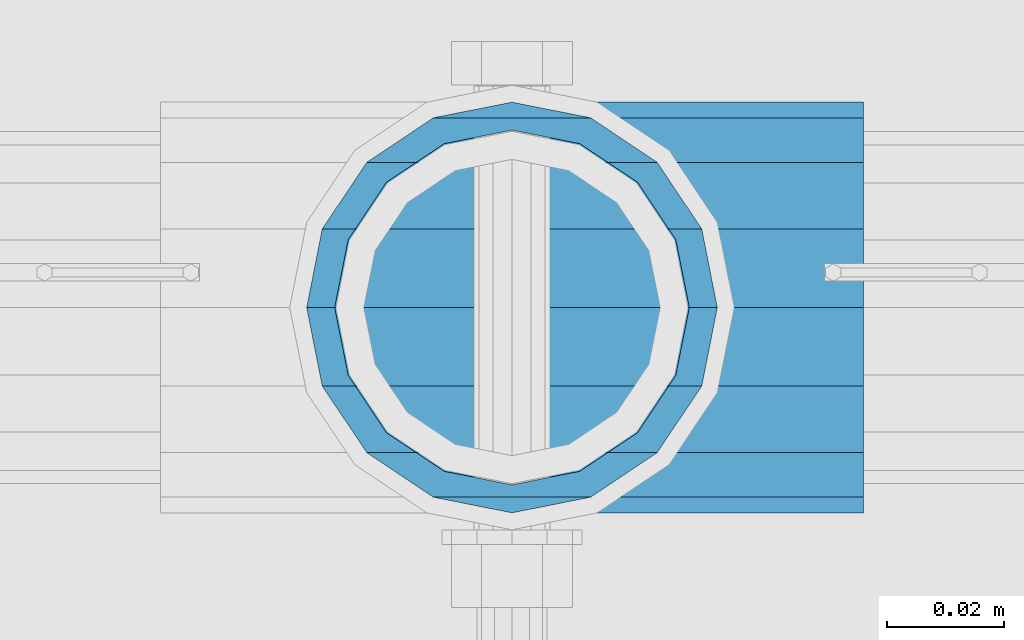
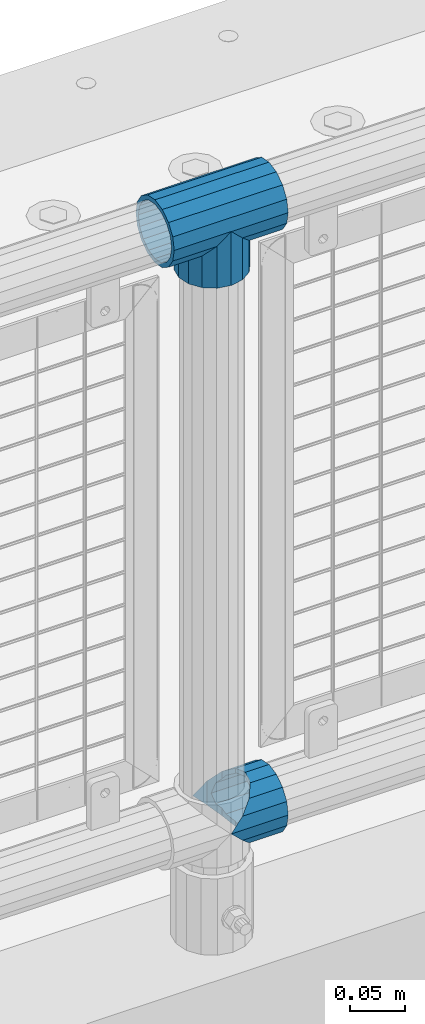
# One storey, part 144 of 242: 3 beams.
"""IFC2X3 building model written with IfcOpenShell, lengths in millimetres."""

import ifcopenshell
import ifcopenshell.guid

model = None  # the IFC model being written
_history = None  # IfcOwnerHistory: only IFC2X3 demands one
_inside = {}  # id of a spatial element -> (the spatial element, [elements in it])
_under = {}  # id of a project, library or spatial element -> (it, [spatial elements below it])
_declared = {}  # id of a project -> (the project, [libraries it declares])
_typed = {}  # id of a type object -> (the type object, [elements of that type])
_made_of = {}  # id of a material, layer set ... -> (it, [elements and type objects made of it])


def new_model(schema):
    """Start an empty IFC model of exactly this schema.

    Asked for "IFC4X3", IfcOpenShell would pick the latest addendum, in which some entities
    have other attributes; the version numbers below select the first issue.
    IFC2X3 requires an IfcOwnerHistory on every rooted entity: one is made here for all.
    """
    global model, _history
    if schema == "IFC4X3":
        model = ifcopenshell.file(schema_version=(4, 3, 0, 0))
    else:
        model = ifcopenshell.file(schema=schema)
    _inside.clear()
    _under.clear()
    _declared.clear()
    _typed.clear()
    _made_of.clear()
    _history = None
    if model.schema == "IFC2X3":
        org = make("IfcOrganization", Name="unknown")
        user = make(
            "IfcPersonAndOrganization",
            ThePerson=make("IfcPerson", FamilyName="unknown"),
            TheOrganization=org,
        )
        app = make(
            "IfcApplication",
            ApplicationDeveloper=org,
            Version="unknown",
            ApplicationFullName="unknown",
            ApplicationIdentifier="unknown",
        )
        _history = make(
            "IfcOwnerHistory",
            OwningUser=user,
            OwningApplication=app,
            ChangeAction="ADDED",
            CreationDate=0,
        )
    return model


def make(cls, **values):
    """One entity of the class cls with the attributes given. An attribute that is None is left unset."""
    return model.create_entity(
        cls, **{name: value for name, value in values.items() if value is not None}
    )


def rooted(cls, **values):
    """An entity with a GlobalId (a new one), such as an element, a storey or a relation."""
    return make(cls, GlobalId=ifcopenshell.guid.new(), OwnerHistory=_history, **values)


def si_unit(unit_type, name, prefix=None):
    """IfcSIUnit, for example si_unit("LENGTHUNIT", "METRE", prefix="MILLI")."""
    return make("IfcSIUnit", UnitType=unit_type, Prefix=prefix, Name=name)


def assignment(units):
    """IfcUnitAssignment: the units of a project."""
    return None if units is None else make("IfcUnitAssignment", Units=units)


def point(xyz):
    """IfcCartesianPoint."""
    return None if xyz is None else make("IfcCartesianPoint", Coordinates=xyz)


def direction(xyz):
    """IfcDirection."""
    return None if xyz is None else make("IfcDirection", DirectionRatios=xyz)


def frame(location, z_axis=None, x_axis=None):
    """IfcAxis2Placement3D, a coordinate frame: its origin and axes. An axis left out is left unset."""
    return make(
        "IfcAxis2Placement3D",
        Location=point(location),
        Axis=direction(z_axis),
        RefDirection=direction(x_axis),
    )


def origin_with_axes():
    """The frame at (0, 0, 0) with the z axis (0, 0, 1) and the x axis (1, 0, 0) written out."""
    return frame((0.0, 0.0, 0.0), z_axis=(0.0, 0.0, 1.0), x_axis=(1.0, 0.0, 0.0))


def place(relative_to, where):
    """IfcLocalPlacement: puts the frame where relative to a parent placement (None: the world)."""
    return make(
        "IfcLocalPlacement", PlacementRelTo=relative_to, RelativePlacement=where
    )


def context(
    kind, dimensions, precision=None, world=None, true_north=None, identifier=None
):
    """IfcGeometricRepresentationContext, for example the 3D "Model" context."""
    return make(
        "IfcGeometricRepresentationContext",
        ContextIdentifier=identifier,
        ContextType=kind,
        CoordinateSpaceDimension=dimensions,
        Precision=precision,
        WorldCoordinateSystem=world,
        TrueNorth=true_north,
    )


def subcontext(parent, identifier, kind, view, scale=None):
    """IfcGeometricRepresentationSubContext, for example "Body" below "Model"."""
    return make(
        "IfcGeometricRepresentationSubContext",
        ContextIdentifier=identifier,
        ContextType=kind,
        ParentContext=parent,
        TargetScale=scale,
        TargetView=view,
    )


def project(units=None, contexts=None):
    """IfcProject with its units and contexts."""
    return rooted(
        "IfcProject",
        Name="project",
        RepresentationContexts=contexts,
        UnitsInContext=assignment(units),
    )


def spatial(cls, under=None, at=None, **own):
    """A site, building, storey or space (cls), placed at a placement, below another one or the project."""
    s = rooted(cls, ObjectPlacement=at, **own)
    if under is not None:
        _under.setdefault(under.id(), (under, []))[1].append(s)
    return s


def faces_of(points, faces, orient=None, outer=None):
    """IfcFace entities. A face is a list of loops; a loop is a list of indices into points, from 0.

    orient and outer hold one flag for each loop. By default every Orientation is true, the
    first loop of a face is its IfcFaceOuterBound and the others are IfcFaceBound.
    """
    made = []
    for i, loops in enumerate(faces):
        bounds = []
        for j, loop in enumerate(loops):
            is_outer = j == 0 if outer is None else outer[i][j]
            bounds.append(
                make(
                    "IfcFaceOuterBound" if is_outer else "IfcFaceBound",
                    Bound=make("IfcPolyLoop", Polygon=[points[k] for k in loop]),
                    Orientation=True if orient is None else orient[i][j],
                )
            )
        made.append(make("IfcFace", Bounds=bounds))
    return made


def faceted_brep(points, faces, orient=None, outer=None, voids=None):
    """IfcFacetedBrep: a solid bounded by flat faces; with voids (closed shells), ...WithVoids."""
    shared = [point(p) for p in points]
    hull = make("IfcClosedShell", CfsFaces=faces_of(shared, faces, orient, outer))
    if voids is None:
        return make("IfcFacetedBrep", Outer=hull)
    return make(
        "IfcFacetedBrepWithVoids",
        Outer=hull,
        Voids=[
            make(cls, CfsFaces=faces_of(shared, fs, o, b)) for cls, fs, o, b in voids
        ],
    )


def shape(context_of_items, identifier, shape_type, items):
    """IfcShapeRepresentation: the items that make up one representation, for example the "Body"."""
    return make(
        "IfcShapeRepresentation",
        ContextOfItems=context_of_items,
        RepresentationIdentifier=identifier,
        RepresentationType=shape_type,
        Items=items,
    )


def material(Name=None, Category=None):
    """IfcMaterial."""
    return make("IfcMaterial", Name=Name, Category=Category)


def made_of(thing, what):
    """Note that an element or type object is made of a material, layer set ...; save() writes the relation."""
    if what is not None:
        _made_of.setdefault(what.id(), (what, []))[1].append(thing)
    return thing


def type_object(cls, material=None, **own):
    """A type object (cls), such as IfcWallType, which elements share."""
    return made_of(rooted(cls, **own), material)


def element(
    cls,
    number,
    at=None,
    inside=None,
    cuts=None,
    type_object=None,
    material=None,
    context=None,
    identifier="Body",
    shape_type=None,
    held_by="IfcProductDefinitionShape",
    body=None,
    shapes=None,
    **own,
):
    """One element of the class cls, such as IfcWall. Its Tag is "e" and its number.

    at: its placement. inside: the storey or other place that contains it. cuts: it is an
    opening in that element (IfcRelVoidsElement). A single representation is given by context,
    identifier, shape_type and body (its items); several are given by shapes. held_by: the class
    of the entity that holds the representations. save() writes the other relations.
    """
    e = rooted(cls, Tag="e%d" % number, ObjectPlacement=at, **own)
    if body is not None:
        shapes = [shape(context, identifier, shape_type, body)]
    if shapes is not None:
        e.Representation = make(held_by, Representations=shapes)
    if inside is not None:
        _inside.setdefault(inside.id(), (inside, []))[1].append(e)
    if cuts is not None:
        rooted(
            "IfcRelVoidsElement", RelatingBuildingElement=cuts, RelatedOpeningElement=e
        )
    if type_object is not None:
        _typed.setdefault(type_object.id(), (type_object, []))[1].append(e)
    return made_of(e, material)


def aggregate(whole, parts):
    """IfcRelAggregates: a whole, such as a stair, and the parts it consists of."""
    return rooted("IfcRelAggregates", RelatingObject=whole, RelatedObjects=parts)


def save(model, path):
    """Write the relations noted so far, then the file.

    IfcRelAggregates (storeys below a building ...), IfcRelContainedInSpatialStructure (elements
    in a storey), IfcRelDefinesByType, IfcRelAssociatesMaterial and IfcRelDeclares: one each for
    every whole, place, type object, material and project.
    """
    for whole, parts in _under.values():
        aggregate(whole, parts)
    for where, things in _inside.values():
        rooted(
            "IfcRelContainedInSpatialStructure",
            RelatedElements=things,
            RelatingStructure=where,
        )
    for kind, things in _typed.values():
        rooted("IfcRelDefinesByType", RelatedObjects=things, RelatingType=kind)
    for what, things in _made_of.values():
        rooted("IfcRelAssociatesMaterial", RelatedObjects=things, RelatingMaterial=what)
    for by, libraries in _declared.values():
        rooted("IfcRelDeclares", RelatingContext=by, RelatedDefinitions=libraries)
    model.write(path)


model = new_model("IFC2X3")

# Units and contexts
model_context = context("Model", 3, precision=1e-05, world=origin_with_axes())
body_context = subcontext(model_context, "Body", "Model", "MODEL_VIEW")
ifc_project = project(units=[si_unit("LENGTHUNIT", "METRE", prefix="MILLI"), si_unit("AREAUNIT", "SQUARE_METRE"), si_unit("VOLUMEUNIT", "CUBIC_METRE"), si_unit("MASSUNIT", "GRAM", prefix="KILO"), si_unit("TIMEUNIT", "SECOND"), si_unit("PLANEANGLEUNIT", "RADIAN"), si_unit("SOLIDANGLEUNIT", "STERADIAN"), si_unit("THERMODYNAMICTEMPERATUREUNIT", "DEGREE_CELSIUS"), si_unit("LUMINOUSINTENSITYUNIT", "LUMEN")], contexts=[model_context])

# Site, building, storey
site_placement = place(None, origin_with_axes())
site = spatial("IfcSite", under=ifc_project, at=site_placement, CompositionType="ELEMENT")
building_placement = place(site_placement, origin_with_axes())
building = spatial("IfcBuilding", under=site, at=building_placement, Name="Standard", CompositionType="ELEMENT")
storey_placement = place(building_placement, origin_with_axes())
storey = spatial("IfcBuildingStorey", under=building, at=storey_placement, Name="Undefined", CompositionType="ELEMENT", Elevation=0.0)

# Beams
ifc_material = material(Name="Misc_Undefined")
beam_type = type_object("IfcBeamType", PredefinedType="NOTDEFINED")
beam_1_placement = place(storey_placement, frame((-40196.0, -19335.5, 298.17), z_axis=(0.0, 1.0, 0.0), x_axis=(1.0, 0.0, 0.0)))
element("IfcBeam", 1, at=beam_1_placement, inside=storey, type_object=beam_type, material=ifc_material, context=body_context, shape_type="Brep", body=[
    faceted_brep([(13.4513226476338, 13.4513226476329, 32.4743655677703), (13.4513226476338, -13.4513226476329, 32.4743655677703), (0.0, 0.0, 35.1500000000015), (27.122676859115, -21.4606908090117, -21.46069080901), (24.8548033587067, -16.3810424080019, -24.8548033587067), (24.8548033587067, -24.8548033587072, -24.8548033587067), (32.4743655677739, -32.4743655677717, -13.4513226476338), (32.4743655677739, -26.8123795176754, -13.4513226476338), (0.0, 0.0, -35.1500000000015), (13.4513226476338, -13.4513226476329, -32.4743655677703), (13.4513226476338, 13.4513226476329, -32.4743655677703), (20.0882031229849, -11.6144421722805, -28.0397438117179), (16.6306603983758, 0.0, -30.3499999999985), (20.0882031229849, 11.6144421722805, -28.0397438117179), (24.8548033587067, 16.3810424079986, -24.8548033587067), (24.8548033587067, 24.8548033587072, -24.8548033587067), (27.122676859115, 21.4606908090117, -21.46069080901), (32.4743655677739, 26.8123795176776, -13.4513226476338), (32.4743655677739, 32.4743655677717, -13.4513226476338), (32.8397438117099, 28.0397438117175, -11.614442172282), (35.1500000000015, 30.35, 0.0), (35.1500000000015, 35.1499999999996, 0.0), (32.8397438117172, 28.0397438117175, 11.614442172282), (32.4743655677739, 26.8123795176754, 13.4513226476338), (32.4743655677739, 32.4743655677717, 13.4513226476338), (27.1226768591077, 21.4606908090117, 21.46069080901), (24.8548033587067, 16.3810424080019, 24.8548033587067), (24.8548033587067, 24.8548033587072, 24.8548033587067), (20.0882031229849, 11.6144421722805, 28.0397438117179), (16.6306603983685, 0.0, 30.3499999999985), (20.0882031229849, -11.6144421722805, 28.0397438117179), (24.8548033587067, -16.3810424080019, 24.8548033587067), (24.8548033587067, -24.8548033587072, 24.8548033587067), (32.4743655677739, -26.8123795176754, 13.4513226476338), (32.4743655677739, -32.4743655677717, 13.4513226476338), (27.1226768591077, -21.4606908090117, 21.46069080901), (35.1500000000015, -30.35, 0.0), (35.1500000000015, -35.15, 0.0), (32.8397438117172, -28.0397438117175, 11.614442172282), (32.8397438117099, -28.0397438117175, -11.614442172282), (60.1500000000015, -24.8548033587072, -24.8548033587067), (60.1500000000015, -32.4743655677717, -13.4513226476338), (60.1500000000015, -13.4513226476329, -32.4743655677703), (60.1500000000015, 0.0, -35.1500000000015), (60.1500000000015, 13.4513226476329, -32.4743655677703), (60.1500000000015, 24.8548033587072, -24.8548033587067), (60.1500000000015, 32.4743655677717, -13.4513226476338), (60.1500000000015, 35.15, 0.0), (60.1500000000015, 32.4743655677717, 13.4513226476338), (60.1500000000015, 24.8548033587072, 24.8548033587067), (60.1500000000015, 13.4513226476329, 32.4743655677703), (60.1500000000015, 0.0, 35.1500000000015), (60.1500000000015, -13.4513226476329, 32.4743655677703), (60.1500000000015, -24.8548033587072, 24.8548033587067), (60.1500000000015, -32.4743655677717, 13.4513226476338), (60.1500000000015, -35.15, 0.0), (60.1500000000015, -21.4606908090117, 21.46069080901), (60.1500000000015, -11.6144421722805, 28.0397438117179), (60.1500000000015, 0.0, 30.3499999999985), (60.1500000000015, 11.6144421722805, 28.0397438117179), (60.1500000000015, 21.4606908090117, 21.46069080901), (60.1500000000015, 28.0397438117175, 11.614442172282), (60.1500000000015, 30.35, 0.0), (60.1500000000015, 28.0397438117175, -11.614442172282), (60.1500000000015, 21.4606908090117, -21.46069080901), (60.1500000000015, 11.6144421722805, -28.0397438117179), (60.1500000000015, 0.0, -30.3499999999985), (60.1500000000015, -11.6144421722805, -28.0397438117179), (60.1500000000015, -21.4606908090117, -21.46069080901), (60.1500000000015, -28.0397438117175, -11.614442172282), (60.1500000000015, -30.35, 0.0), (60.1500000000015, -28.0397438117175, 11.614442172282)], [[[0, 1, 2]], [[3, 4, 5, 6, 7]], [[8, 9, 10]], [[10, 9, 5, 4, 11, 12, 13, 14, 15]], [[15, 14, 16, 17, 18]], [[18, 17, 19, 20, 21]], [[21, 20, 22, 23, 24]], [[24, 23, 25, 26, 27]], [[27, 26, 28, 29, 30, 31, 32, 1, 0]], [[33, 34, 32, 31, 35]], [[36, 37, 34, 33, 38]], [[39, 7, 6, 37, 36]], [[40, 41, 6, 5]], [[42, 40, 5, 9]], [[43, 42, 9, 8]], [[44, 43, 8, 10]], [[45, 44, 10, 15]], [[46, 45, 15, 18]], [[47, 46, 18, 21]], [[48, 47, 21, 24]], [[49, 48, 24, 27]], [[50, 49, 27, 0]], [[51, 50, 0, 2]], [[52, 51, 2, 1]], [[53, 52, 1, 32]], [[54, 53, 32, 34]], [[55, 54, 34, 37]], [[41, 55, 37, 6]], [[40, 42, 43, 44, 45, 46, 47, 48, 49, 50, 51, 52, 53, 54, 55, 41], [56, 57, 58, 59, 60, 61, 62, 63, 64, 65, 66, 67, 68, 69, 70, 71]], [[71, 70, 36, 38]], [[35, 56, 71, 38, 33]], [[30, 57, 56, 35, 31]], [[58, 57, 30, 29]], [[59, 58, 29, 28]], [[60, 59, 28, 26, 25]], [[61, 60, 25, 23, 22]], [[62, 61, 22, 20]], [[63, 62, 20, 19]], [[16, 64, 63, 19, 17]], [[13, 65, 64, 16, 14]], [[66, 65, 13, 12]], [[67, 66, 12, 11]], [[68, 67, 11, 4, 3]], [[69, 68, 3, 7, 39]], [[70, 69, 39, 36]]]),
])
beam_2_placement = place(storey_placement, frame((-40196.0, -19335.5, 969.849999999999), z_axis=(0.0, 1.0, 0.0), x_axis=(0.0, 0.0, -1.0)))
element("IfcBeam", 2, at=beam_2_placement, inside=storey, type_object=beam_type, material=ifc_material, context=body_context, shape_type="Brep", body=[
    faceted_brep([(13.4513226476338, 13.4513226476329, 32.4743655677703), (13.4513226476338, -13.4513226476329, 32.4743655677703), (0.0, 0.0, 35.1500000000015), (27.122676859115, -21.4606908090117, -21.46069080901), (24.8548033587067, -16.3810424080019, -24.8548033587067), (24.8548033587067, -24.8548033587072, -24.8548033587067), (32.4743655677739, -32.4743655677717, -13.4513226476338), (32.4743655677739, -26.8123795176754, -13.4513226476338), (0.0, 0.0, -35.1500000000015), (13.4513226476338, -13.4513226476329, -32.4743655677703), (13.4513226476338, 13.4513226476329, -32.4743655677703), (20.0882031229849, -11.6144421722805, -28.0397438117179), (16.6306603983758, 0.0, -30.3499999999985), (20.0882031229849, 11.6144421722805, -28.0397438117179), (24.8548033587067, 16.3810424079986, -24.8548033587067), (24.8548033587067, 24.8548033587072, -24.8548033587067), (27.122676859115, 21.4606908090117, -21.46069080901), (32.4743655677739, 26.8123795176776, -13.4513226476338), (32.4743655677739, 32.4743655677717, -13.4513226476338), (32.8397438117099, 28.0397438117175, -11.614442172282), (35.1500000000015, 30.35, 0.0), (35.1500000000015, 35.1499999999996, 0.0), (32.8397438117172, 28.0397438117175, 11.614442172282), (32.4743655677739, 26.8123795176754, 13.4513226476338), (32.4743655677739, 32.4743655677717, 13.4513226476338), (27.1226768591077, 21.4606908090117, 21.46069080901), (24.8548033587067, 16.3810424080019, 24.8548033587067), (24.8548033587067, 24.8548033587072, 24.8548033587067), (20.0882031229849, 11.6144421722805, 28.0397438117179), (16.6306603983685, 0.0, 30.3499999999985), (20.0882031229849, -11.6144421722805, 28.0397438117179), (24.8548033587067, -16.3810424080019, 24.8548033587067), (24.8548033587067, -24.8548033587072, 24.8548033587067), (32.4743655677739, -26.8123795176754, 13.4513226476338), (32.4743655677739, -32.4743655677717, 13.4513226476338), (27.1226768591077, -21.4606908090117, 21.46069080901), (35.1500000000015, -30.35, 0.0), (35.1500000000015, -35.15, 0.0), (32.8397438117172, -28.0397438117175, 11.614442172282), (32.8397438117099, -28.0397438117175, -11.614442172282), (60.1500000000015, -24.8548033587072, -24.8548033587067), (60.1500000000015, -32.4743655677717, -13.4513226476338), (60.1500000000015, -13.4513226476329, -32.4743655677703), (60.1500000000015, 0.0, -35.1500000000015), (60.1500000000015, 13.4513226476329, -32.4743655677703), (60.1500000000015, 24.8548033587072, -24.8548033587067), (60.1500000000015, 32.4743655677717, -13.4513226476338), (60.1500000000015, 35.15, 0.0), (60.1500000000015, 32.4743655677717, 13.4513226476338), (60.1500000000015, 24.8548033587072, 24.8548033587067), (60.1500000000015, 13.4513226476329, 32.4743655677703), (60.1500000000015, 0.0, 35.1500000000015), (60.1500000000015, -13.4513226476329, 32.4743655677703), (60.1500000000015, -24.8548033587072, 24.8548033587067), (60.1500000000015, -32.4743655677717, 13.4513226476338), (60.1500000000015, -35.15, 0.0), (60.1500000000015, -21.4606908090117, 21.46069080901), (60.1500000000015, -11.6144421722805, 28.0397438117179), (60.1500000000015, 0.0, 30.3499999999985), (60.1500000000015, 11.6144421722805, 28.0397438117179), (60.1500000000015, 21.4606908090117, 21.46069080901), (60.1500000000015, 28.0397438117175, 11.614442172282), (60.1500000000015, 30.35, 0.0), (60.1500000000015, 28.0397438117175, -11.614442172282), (60.1500000000015, 21.4606908090117, -21.46069080901), (60.1500000000015, 11.6144421722805, -28.0397438117179), (60.1500000000015, 0.0, -30.3499999999985), (60.1500000000015, -11.6144421722805, -28.0397438117179), (60.1500000000015, -21.4606908090117, -21.46069080901), (60.1500000000015, -28.0397438117175, -11.614442172282), (60.1500000000015, -30.35, 0.0), (60.1500000000015, -28.0397438117175, 11.614442172282)], [[[0, 1, 2]], [[3, 4, 5, 6, 7]], [[8, 9, 10]], [[10, 9, 5, 4, 11, 12, 13, 14, 15]], [[15, 14, 16, 17, 18]], [[18, 17, 19, 20, 21]], [[21, 20, 22, 23, 24]], [[24, 23, 25, 26, 27]], [[27, 26, 28, 29, 30, 31, 32, 1, 0]], [[33, 34, 32, 31, 35]], [[36, 37, 34, 33, 38]], [[39, 7, 6, 37, 36]], [[40, 41, 6, 5]], [[42, 40, 5, 9]], [[43, 42, 9, 8]], [[44, 43, 8, 10]], [[45, 44, 10, 15]], [[46, 45, 15, 18]], [[47, 46, 18, 21]], [[48, 47, 21, 24]], [[49, 48, 24, 27]], [[50, 49, 27, 0]], [[51, 50, 0, 2]], [[52, 51, 2, 1]], [[53, 52, 1, 32]], [[54, 53, 32, 34]], [[55, 54, 34, 37]], [[41, 55, 37, 6]], [[40, 42, 43, 44, 45, 46, 47, 48, 49, 50, 51, 52, 53, 54, 55, 41], [56, 57, 58, 59, 60, 61, 62, 63, 64, 65, 66, 67, 68, 69, 70, 71]], [[71, 70, 36, 38]], [[35, 56, 71, 38, 33]], [[30, 57, 56, 35, 31]], [[58, 57, 30, 29]], [[59, 58, 29, 28]], [[60, 59, 28, 26, 25]], [[61, 60, 25, 23, 22]], [[62, 61, 22, 20]], [[63, 62, 20, 19]], [[16, 64, 63, 19, 17]], [[13, 65, 64, 16, 14]], [[66, 65, 13, 12]], [[67, 66, 12, 11]], [[68, 67, 11, 4, 3]], [[69, 68, 3, 7, 39]], [[70, 69, 39, 36]]]),
])
beam_3_placement = place(storey_placement, frame((-40256.15, -19335.5, 969.849999999999), z_axis=(0.0, 0.0, 1.0), x_axis=(1.0, 0.0, 0.0)))
element("IfcBeam", 3, at=beam_3_placement, inside=storey, type_object=beam_type, material=ifc_material, context=body_context, shape_type="Brep", body=[
    faceted_brep([(88.1897438117194, -11.614442172282, -28.0397438117176), (88.1897438117194, -11.614442172282, -32.8397438117175), (86.9623795176813, -13.4513226476338, -32.4743655677718), (81.6106908090114, -21.46069080901, -27.12267685911), (81.6106908090114, -21.46069080901, -21.4606908090117), (76.5310424080017, -24.8548033587067, -24.8548033587072), (71.7644421722835, -28.0397438117179, -20.0882031229829), (71.7644421722835, -28.0397438117179, -11.6144421722805), (60.1500000000015, -30.3499999999985, -16.6306603983671), (60.1500000000015, -30.35, 0.0), (48.5355578277195, -28.0397438117179, -20.0882031229829), (48.5355578277195, -28.0397438117179, -11.6144421722805), (43.7689575920012, -24.8548033587067, -24.8548033587072), (38.6893091909915, -21.46069080901, -27.12267685911), (38.6893091909915, -21.46069080901, -21.4606908090117), (33.3376204823289, -13.4513226476338, -32.4743655677718), (32.1102561882835, -11.614442172282, -32.8397438117175), (32.1102561882835, -11.614442172282, -28.0397438117176), (29.8000000000029, 0.0, -35.15), (29.8000000000029, 0.0, -30.35), (32.1102561882835, 11.614442172282, -32.8397438117171), (32.1102561882835, 11.614442172282, -28.0397438117176), (33.3376204823253, 13.4513226476338, -32.4743655677718), (38.6893091909915, 21.46069080901, -27.12267685911), (38.6893091909915, 21.46069080901, -21.4606908090117), (43.7689575920012, 24.8548033587067, -24.8548033587072), (48.5355578277195, 28.0397438117179, -20.0882031229861), (48.5355578277195, 28.0397438117179, -11.6144421722805), (60.1500000000015, 30.3499999999985, -16.6306603983737), (60.1500000000015, 30.35, 0.0), (71.7644421722835, 28.0397438117179, -20.0882031229861), (71.7644421722835, 28.0397438117179, -11.6144421722805), (76.5310424080017, 24.8548033587067, -24.8548033587072), (81.6106908090114, 21.46069080901, -27.12267685911), (81.6106908090114, 21.46069080901, -21.4606908090117), (86.9623795176667, 13.4513226476338, -32.4743655677718), (88.1897438117194, 11.614442172282, -32.8397438117171), (88.1897438117194, 11.614442172282, -28.0397438117176), (90.5, 0.0, -35.15), (90.5, 0.0, -30.35), (0.0, -21.46069080901, -21.4606908090136), (0.0, -28.0397438117179, -11.6144421722784), (0.0, -11.614442172282, -28.0397438117143), (0.0, 0.0, -30.3499999999985), (0.0, 11.614442172282, -28.0397438117143), (0.0, 21.46069080901, -21.4606908090136), (0.0, 28.0397438117179, -11.6144421722784), (0.0, 30.3499999999985, 0.0), (0.0, 32.4743655677703, -13.4513226476338), (0.0, 35.1500000000015, 0.0), (120.299999999999, 35.1500000000015, 0.0), (120.299999999999, 32.4743655677703, -13.4513226476329), (0.0, 32.4743655677703, 13.4513226476338), (120.299999999999, 32.4743655677703, 13.4513226476329), (0.0, 24.8548033587067, 24.8548033587067), (120.299999999999, 24.8548033587067, 24.8548033587072), (0.0, 13.4513226476338, 32.4743655677739), (120.299999999999, 13.4513226476338, 32.4743655677718), (0.0, 0.0, 35.1500000000015), (120.299999999999, 0.0, 35.15), (0.0, -13.4513226476338, 32.4743655677739), (120.299999999999, -13.4513226476338, 32.4743655677718), (0.0, -24.8548033587067, 24.8548033587067), (120.299999999999, -24.8548033587067, 24.8548033587072), (0.0, -32.4743655677703, 13.4513226476338), (120.299999999999, -32.4743655677703, 13.4513226476329), (0.0, -35.1500000000015, 0.0), (120.299999999999, -35.1500000000015, 0.0), (0.0, -32.4743655677703, -13.4513226476338), (120.299999999999, -32.4743655677703, -13.4513226476329), (0.0, 24.8548033587067, -24.8548033587067), (0.0, 13.4513226476338, -32.4743655677739), (0.0, 0.0, -35.1500000000015), (0.0, -13.4513226476338, -32.4743655677739), (0.0, -24.8548033587067, -24.8548033587067), (0.0, 28.0397438117179, 11.6144421722784), (0.0, 21.46069080901, 21.4606908090136), (0.0, 11.614442172282, 28.0397438117143), (0.0, 0.0, 30.3499999999985), (0.0, -11.614442172282, 28.0397438117143), (0.0, -21.46069080901, 21.4606908090136), (0.0, -28.0397438117179, 11.6144421722784), (0.0, -30.3499999999985, 0.0), (120.299999999999, -30.3499999999985, 0.0), (120.299999999999, -28.0397438117179, -11.6144421722805), (120.299999999999, -21.46069080901, -21.4606908090117), (120.299999999999, -11.614442172282, -28.0397438117176), (120.299999999999, 0.0, -30.35), (120.299999999999, 21.46069080901, -21.4606908090117), (120.299999999999, 28.0397438117179, -11.6144421722805), (120.299999999999, 11.614442172282, -28.0397438117176), (120.299999999999, 30.3499999999985, 0.0), (120.299999999999, 28.0397438117179, 11.6144421722805), (120.299999999999, 21.46069080901, 21.4606908090117), (120.299999999999, 11.614442172282, 28.0397438117176), (120.299999999999, 0.0, 30.35), (120.299999999999, -11.614442172282, 28.0397438117176), (120.299999999999, -21.46069080901, 21.4606908090117), (120.299999999999, -28.0397438117179, 11.6144421722805), (120.299999999999, -24.8548033587067, -24.8548033587072), (120.299999999999, -13.4513226476338, -32.4743655677718), (120.299999999999, 0.0, -35.15), (120.299999999999, 13.4513226476338, -32.4743655677718), (120.299999999999, 24.8548033587067, -24.8548033587072)], [[[0, 1, 2, 3, 4]], [[4, 3, 5, 6, 7]], [[7, 6, 8, 9]], [[9, 8, 10, 11]], [[11, 10, 12, 13, 14]], [[14, 13, 15, 16, 17]], [[17, 16, 18, 19]], [[19, 18, 20, 21]], [[21, 20, 22, 23, 24]], [[24, 23, 25, 26, 27]], [[27, 26, 28, 29]], [[29, 28, 30, 31]], [[31, 30, 32, 33, 34]], [[34, 33, 35, 36, 37]], [[37, 36, 38, 39]], [[39, 38, 1, 0]], [[40, 41, 11, 14]], [[42, 40, 14, 17]], [[43, 42, 17, 19]], [[44, 43, 19, 21]], [[45, 44, 21, 24]], [[46, 45, 24, 27]], [[47, 46, 27, 29]], [[48, 49, 50, 51]], [[49, 52, 53, 50]], [[52, 54, 55, 53]], [[54, 56, 57, 55]], [[56, 58, 59, 57]], [[58, 60, 61, 59]], [[60, 62, 63, 61]], [[62, 64, 65, 63]], [[64, 66, 67, 65]], [[66, 68, 69, 67]], [[64, 62, 60, 58, 56, 54, 52, 49, 48, 70, 71, 72, 73, 74, 68, 66], [41, 40, 42, 43, 44, 45, 46, 47, 75, 76, 77, 78, 79, 80, 81, 82]], [[41, 82, 9, 11]], [[83, 84, 7, 9]], [[84, 85, 4, 7]], [[85, 86, 0, 4]], [[86, 87, 39, 0]], [[88, 89, 31, 34]], [[90, 88, 34, 37]], [[87, 90, 37, 39]], [[89, 91, 29, 31]], [[75, 47, 29, 91, 92]], [[76, 75, 92, 93]], [[77, 76, 93, 94]], [[78, 77, 94, 95]], [[79, 78, 95, 96]], [[80, 79, 96, 97]], [[81, 80, 97, 98]], [[9, 82, 81, 98, 83]], [[99, 100, 101, 102, 103, 51, 50, 53, 55, 57, 59, 61, 63, 65, 67, 69], [97, 96, 95, 94, 93, 92, 91, 89, 88, 90, 87, 86, 85, 84, 83, 98]], [[35, 102, 101, 38, 36]], [[32, 103, 102, 35, 33]], [[28, 26, 25, 70, 48, 51, 103, 32, 30]], [[22, 71, 70, 25, 23]], [[18, 72, 71, 22, 20]], [[73, 72, 18, 16, 15]], [[74, 73, 15, 13, 12]], [[99, 69, 68, 74, 12, 10, 8, 6, 5]], [[100, 99, 5, 3, 2]], [[101, 100, 2, 1, 38]]]),
])

save(model, "model.ifc")
